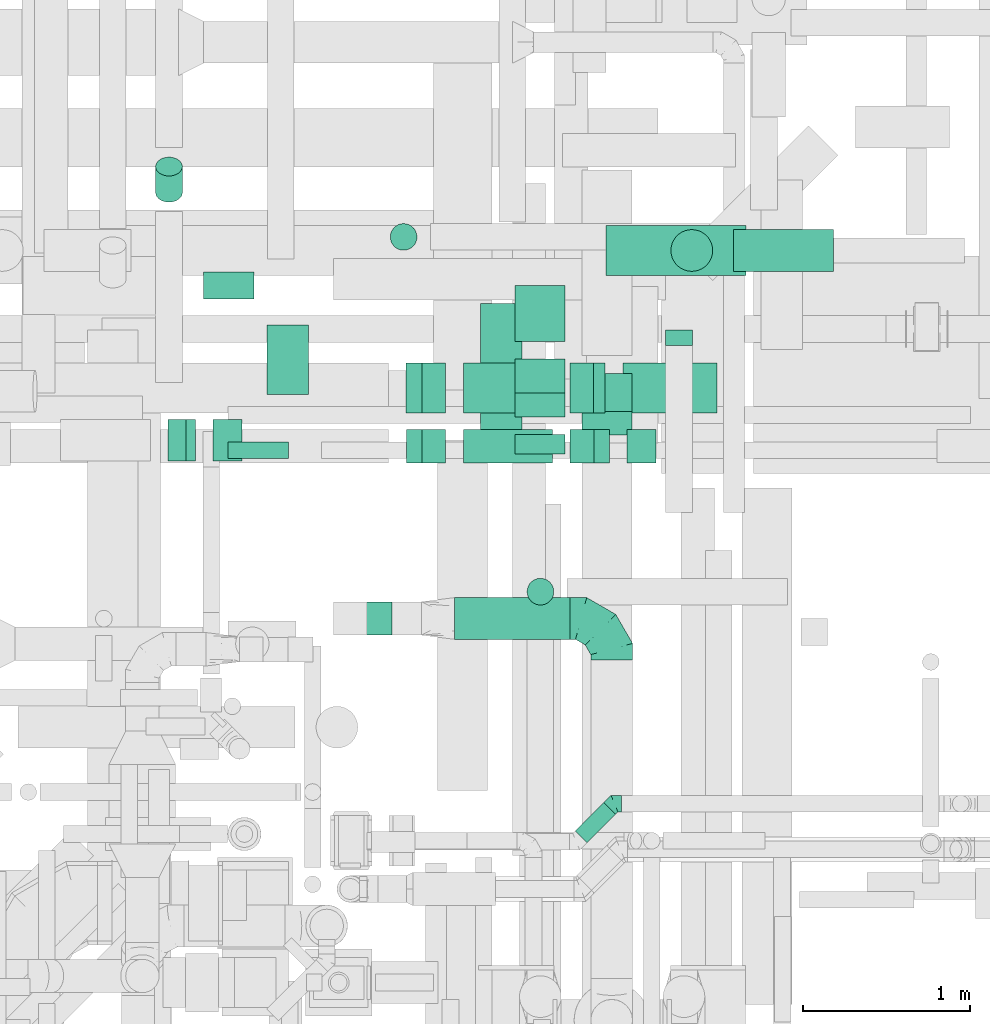
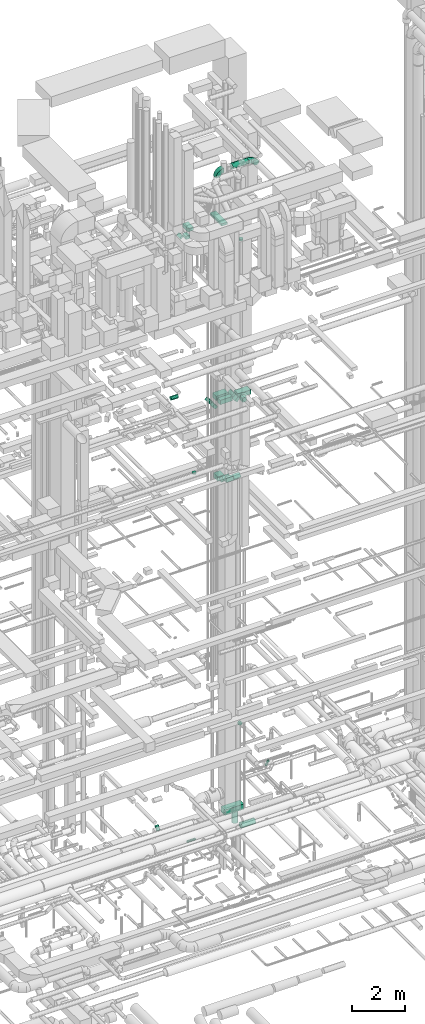
# One storey, part 251 of 337: 26 flow segments, 4 flow fittings.
"""IFC2X3 building model written with IfcOpenShell, lengths in millimetres."""

from ifc_helpers import new_model, entity, si_unit, converted_unit, derived_unit, direction, frame, frame_2d, origin, origin_2d_with_axis, place, context, subcontext, project, spatial, polyline, circle_curve, parameter, trimmed, segment, composite_curve, rectangle, circle, outline, extrude, faceted_brep, source, transform, mapped, material, type_object, type_shapes, element, save


model = new_model("IFC2X3")

# Units and contexts
model_context = context("Model", 3, precision=0.01, world=origin(), true_north=direction((6.12303176911189e-17, 1.0)))
body_context = subcontext(model_context, "Body", "Model", "MODEL_VIEW")
ifc_project = project(units=[si_unit("LENGTHUNIT", "METRE", prefix="MILLI"), si_unit("AREAUNIT", "SQUARE_METRE"), si_unit("VOLUMEUNIT", "CUBIC_METRE"), converted_unit("PLANEANGLEUNIT", "DEGREE", entity("IfcRatioMeasure", 0.0174532925199433), si_unit("PLANEANGLEUNIT", "RADIAN"), dimensions=[0, 0, 0, 0, 0, 0, 0]), si_unit("MASSUNIT", "GRAM", prefix="KILO"), derived_unit("MASSDENSITYUNIT", [(si_unit("MASSUNIT", "GRAM", prefix="KILO"), 1), (si_unit("LENGTHUNIT", "METRE"), -3)]), derived_unit("MOMENTOFINERTIAUNIT", [(si_unit("LENGTHUNIT", "METRE"), 4)]), si_unit("TIMEUNIT", "SECOND"), si_unit("FREQUENCYUNIT", "HERTZ"), si_unit("THERMODYNAMICTEMPERATUREUNIT", "DEGREE_CELSIUS"), derived_unit("THERMALTRANSMITTANCEUNIT", [(si_unit("MASSUNIT", "GRAM", prefix="KILO"), 1), (si_unit("THERMODYNAMICTEMPERATUREUNIT", "KELVIN"), -1), (si_unit("TIMEUNIT", "SECOND"), -3)]), derived_unit("VOLUMETRICFLOWRATEUNIT", [(si_unit("LENGTHUNIT", "METRE"), 3), (si_unit("TIMEUNIT", "SECOND"), -1)]), derived_unit("MASSFLOWRATEUNIT", [(si_unit("MASSUNIT", "GRAM", prefix="KILO"), 1), (si_unit("TIMEUNIT", "SECOND"), -1)]), derived_unit("ROTATIONALFREQUENCYUNIT", [(si_unit("TIMEUNIT", "SECOND"), -1)]), si_unit("ELECTRICCURRENTUNIT", "AMPERE"), si_unit("ELECTRICVOLTAGEUNIT", "VOLT"), si_unit("POWERUNIT", "WATT"), si_unit("FORCEUNIT", "NEWTON", prefix="KILO"), si_unit("ILLUMINANCEUNIT", "LUX"), si_unit("LUMINOUSFLUXUNIT", "LUMEN"), si_unit("LUMINOUSINTENSITYUNIT", "CANDELA"), derived_unit("USERDEFINED", [(si_unit("MASSUNIT", "GRAM", prefix="KILO"), -1), (si_unit("LENGTHUNIT", "METRE"), -2), (si_unit("TIMEUNIT", "SECOND"), 3), (si_unit("LUMINOUSFLUXUNIT", "LUMEN"), 1)]), derived_unit("LINEARVELOCITYUNIT", [(si_unit("LENGTHUNIT", "METRE"), 1), (si_unit("TIMEUNIT", "SECOND"), -1)]), si_unit("PRESSUREUNIT", "PASCAL"), derived_unit("USERDEFINED", [(si_unit("LENGTHUNIT", "METRE"), -2), (si_unit("MASSUNIT", "GRAM", prefix="KILO"), 1), (si_unit("TIMEUNIT", "SECOND"), -2)]), derived_unit("LINEARFORCEUNIT", [(si_unit("MASSUNIT", "GRAM", prefix="KILO"), 1), (si_unit("LENGTHUNIT", "METRE"), 1), (si_unit("TIMEUNIT", "SECOND"), -2), (si_unit("LENGTHUNIT", "METRE"), -1)]), derived_unit("PLANARFORCEUNIT", [(si_unit("MASSUNIT", "GRAM", prefix="KILO"), 1), (si_unit("LENGTHUNIT", "METRE"), 1), (si_unit("TIMEUNIT", "SECOND"), -2), (si_unit("LENGTHUNIT", "METRE"), -2)])], contexts=[model_context])

# Site, building, storey
site_placement = place(None, origin())
site = spatial("IfcSite", under=ifc_project, at=site_placement, CompositionType="ELEMENT")
building_placement = place(site_placement, origin())
building = spatial("IfcBuilding", under=site, at=building_placement, CompositionType="ELEMENT")
storey_placement = place(building_placement, origin())
storey = spatial("IfcBuildingStorey", under=building, at=storey_placement, CompositionType="ELEMENT", Elevation=0.0)

# Flow segments
duct_segment_type_1 = type_object("IfcDuctSegmentType", PredefinedType="NOTDEFINED")
flow_segment_1_placement = place(storey_placement, frame((61080.93, 15198.96, -975.0)))
element("IfcFlowSegment", 1, at=flow_segment_1_placement, inside=storey, type_object=duct_segment_type_1, context=body_context, shape_type="SweptSolid", body=[
    extrude(rectangle(XDim=839.433055887242, YDim=300.000000000001, at=origin_2d_with_axis()), frame((419.72, 150.0, 0.0)), (0.0, 0.0, 1.0), 250.0),
])
flow_segment_2_placement = place(storey_placement, frame((61208.02, 14075.53, 18750.0)))
element("IfcFlowSegment", 2, at=flow_segment_2_placement, inside=storey, type_object=duct_segment_type_1, context=body_context, shape_type="SweptSolid", body=[
    extrude(rectangle(XDim=172.037818770773, YDim=200.0, at=origin_2d_with_axis()), frame((86.02, 100.0, 0.0), z_axis=(0.0, 0.0, 1.0), x_axis=(-1.0, 0.0, 0.0)), (0.0, 0.0, 1.0), 200.000000000002),
])
flow_segment_3_placement = place(storey_placement, frame((60537.19, 14803.93, 14900.0)))
element("IfcFlowSegment", 3, at=flow_segment_3_placement, inside=storey, type_object=duct_segment_type_1, context=body_context, shape_type="SweptSolid", body=[
    extrude(rectangle(XDim=336.066847245268, YDim=300.000000000001, at=origin_2d_with_axis()), frame((150.0, 168.03, 0.0), z_axis=(0.0, 0.0, 1.0), x_axis=(0.0, -1.0, 0.0)), (0.0, 0.0, 1.0), 199.999999999998),
])
flow_segment_4_placement = place(storey_placement, frame((60537.19, 14129.66, 15250.0)))
element("IfcFlowSegment", 4, at=flow_segment_4_placement, inside=storey, type_object=duct_segment_type_1, context=body_context, shape_type="SweptSolid", body=[
    extrude(rectangle(XDim=117.166588713052, YDim=300.000000000001, at=origin_2d_with_axis()), frame((150.0, 58.58, 0.0), z_axis=(0.0, 0.0, 1.0), x_axis=(0.0, 1.0, 0.0)), (0.0, 0.0, 1.0), 199.999999999998),
])
flow_segment_5_placement = place(storey_placement, frame((60537.19, 14352.89, 15002.51)))
element("IfcFlowSegment", 5, at=flow_segment_5_placement, inside=storey, type_object=duct_segment_type_1, context=body_context, shape_type="SweptSolid", body=[
    extrude(rectangle(XDim=287.867907553649, YDim=200.000000000001, at=origin_2d_with_axis()), frame((0.0, 172.49, 172.49), z_axis=(1.0, 0.0, 0.0), x_axis=(0.0, 0.707106781186506, -0.707106781186589)), (0.0, 0.0, 1.0), 300.000000000001),
])
flow_segment_6_placement = place(storey_placement, frame((61182.64, 14375.32, 18775.0)))
element("IfcFlowSegment", 6, at=flow_segment_6_placement, inside=storey, type_object=duct_segment_type_1, context=body_context, shape_type="SweptSolid", body=[
    extrude(rectangle(XDim=562.010880577353, YDim=300.000000000001, at=origin_2d_with_axis()), frame((281.01, 150.0, 0.0)), (0.0, 0.0, 1.0), 200.000000000002),
])
flow_segment_7_placement = place(storey_placement, frame((59884.49, 14375.32, 18852.51)))
element("IfcFlowSegment", 7, at=flow_segment_7_placement, inside=storey, type_object=duct_segment_type_1, context=body_context, shape_type="SweptSolid", body=[
    extrude(rectangle(XDim=199.999999999995, YDim=133.794193046487, at=frame_2d((0.0, 0.0), x_axis=(0.0, 1.0))), frame((118.01, 0.0, 118.01), z_axis=(0.0, 1.0, 0.0), x_axis=(0.707106781186637, 0.0, 0.707106781186459)), (0.0, 0.0, 1.0), 299.999999999999),
])
flow_segment_8_placement = place(storey_placement, frame((60226.59, 14375.32, 18991.05)))
element("IfcFlowSegment", 8, at=flow_segment_8_placement, inside=storey, type_object=duct_segment_type_1, context=body_context, shape_type="SweptSolid", body=[
    extrude(rectangle(XDim=532.893218813475, YDim=300.000000000001, at=origin_2d_with_axis()), frame((266.45, 150.0, 0.0)), (0.0, 0.0, 1.0), 200.000000000002),
])
flow_segment_9_placement = place(storey_placement, frame((60865.55, 14375.32, 18877.51)))
element("IfcFlowSegment", 9, at=flow_segment_9_placement, inside=storey, type_object=duct_segment_type_1, context=body_context, shape_type="SweptSolid", body=[
    extrude(rectangle(XDim=200.000000000003, YDim=98.4388539871063, at=frame_2d((0.0, 0.0), x_axis=(0.0, 1.0))), frame((105.51, 0.0, 105.51), z_axis=(0.0, 1.0, 0.0), x_axis=(0.707106781186581, 0.0, -0.707106781186514)), (0.0, 0.0, 1.0), 300.000000000001),
])
flow_segment_10_placement = place(storey_placement, frame((59886.15, 14075.53, 18852.51)))
element("IfcFlowSegment", 10, at=flow_segment_10_placement, inside=storey, type_object=duct_segment_type_1, context=body_context, shape_type="SweptSolid", body=[
    extrude(rectangle(XDim=132.893218813456, YDim=200.0, at=origin_2d_with_axis()), frame((46.98, 100.0, 188.41), z_axis=(0.707106781186621, 0.0, -0.707106781186474), x_axis=(0.707106781186474, 0.0, 0.707106781186621)), (0.0, 0.0, 1.0), 200.000000000011),
])
flow_segment_11_placement = place(storey_placement, frame((60227.6, 14075.53, 18990.42)))
element("IfcFlowSegment", 11, at=flow_segment_11_placement, inside=storey, type_object=duct_segment_type_1, context=body_context, shape_type="SweptSolid", body=[
    extrude(rectangle(XDim=532.893218813526, YDim=200.0, at=origin_2d_with_axis()), frame((266.45, 100.0, 0.0)), (0.0, 0.0, 1.0), 200.000000000002),
])
flow_segment_12_placement = place(storey_placement, frame((60866.56, 14075.53, 18852.51)))
element("IfcFlowSegment", 12, at=flow_segment_12_placement, inside=storey, type_object=duct_segment_type_1, context=body_context, shape_type="SweptSolid", body=[
    extrude(rectangle(XDim=132.893218813424, YDim=200.000000000003, at=origin_2d_with_axis()), frame((117.7, 0.0, 117.7), z_axis=(0.0, 1.0, 0.0), x_axis=(0.70710678118645, 0.0, -0.707106781186645)), (0.0, 0.0, 1.0), 200.0),
])
flow_segment_13_placement = place(storey_placement, frame((60938.43, 14242.46, 14977.51)))
element("IfcFlowSegment", 13, at=flow_segment_13_placement, inside=storey, type_object=duct_segment_type_1, context=body_context, shape_type="SweptSolid", body=[
    extrude(rectangle(XDim=200.000000000001, YDim=300.000000000001, at=frame_2d((0.0, 0.0), x_axis=(0.0, 1.0))), frame((150.0, 299.26, 70.71), z_axis=(0.0, -0.707106781186493, 0.707106781186602), x_axis=(1.0, 0.0, 0.0)), (0.0, 0.0, 1.0), 323.222166174818),
])
flow_segment_14_placement = place(storey_placement, frame((59050.82, 14487.02, 27135.0)))
element("IfcFlowSegment", 14, at=flow_segment_14_placement, inside=storey, type_object=duct_segment_type_1, context=body_context, shape_type="SweptSolid", body=[
    extrude(rectangle(XDim=415.000000000072, YDim=250.000000000004, at=origin_2d_with_axis()), frame((125.0, 207.5, 0.0), z_axis=(0.0, 0.0, 1.0), x_axis=(0.0, 1.0, 0.0)), (0.0, 0.0, 1.0), 150.000000000001),
])
flow_segment_15_placement = place(storey_placement, frame((58458.69, 14087.02, 27222.87)))
element("IfcFlowSegment", 15, at=flow_segment_15_placement, inside=storey, type_object=duct_segment_type_1, context=body_context, shape_type="SweptSolid", body=[
    extrude(rectangle(XDim=82.3044737829602, YDim=149.999999999996, at=origin_2d_with_axis()), frame((82.13, 0.0, 82.13), z_axis=(0.0, 1.0, 0.0), x_axis=(0.707106781186442, 0.0, -0.707106781186653)), (0.0, 0.0, 1.0), 249.999999999997),
])
flow_segment_16_placement = place(storey_placement, frame((58729.02, 14087.02, 27135.0)))
element("IfcFlowSegment", 16, at=flow_segment_16_placement, inside=storey, type_object=duct_segment_type_1, context=body_context, shape_type="SweptSolid", body=[
    extrude(rectangle(XDim=171.801948466095, YDim=249.999999999999, at=origin_2d_with_axis()), frame((85.9, 125.0, 0.0), z_axis=(0.0, 0.0, 1.0), x_axis=(-1.0, 0.0, 0.0)), (0.0, 0.0, 1.0), 150.000000000001),
])
flow_segment_17_placement = place(storey_placement, frame((60328.86, 14152.02, 27160.0)))
element("IfcFlowSegment", 17, at=flow_segment_17_placement, inside=storey, type_object=duct_segment_type_1, context=body_context, shape_type="SweptSolid", body=[
    extrude(rectangle(XDim=879.999999999991, YDim=250.000000000004, at=origin_2d_with_axis()), frame((125.0, 440.0, 0.0), z_axis=(0.0, 0.0, 1.0), x_axis=(0.0, -1.0, 0.0)), (0.0, 0.0, 1.0), 100.000000000003),
])
duct_segment_type_2 = type_object("IfcDuctSegmentType", PredefinedType="NOTDEFINED")
flow_segment_18_placement = place(storey_placement, frame((61468.48, 15222.36, -1530.0)))
element("IfcFlowSegment", 18, at=flow_segment_18_placement, inside=storey, type_object=duct_segment_type_2, context=body_context, shape_type="SweptSolid", body=[
    extrude(circle(Radius=125.0, at=origin_2d_with_axis()), frame((126.6, 126.6, 0.0), z_axis=(0.0, 0.0, 1.0), x_axis=(-1.0, 0.0, 0.0)), (0.0, 0.0, 1.0), 535.000024999841),
])
flow_segment_19_placement = place(storey_placement, frame((61845.08, 15222.36, -1906.6)))
element("IfcFlowSegment", 19, at=flow_segment_19_placement, inside=storey, type_object=duct_segment_type_2, context=body_context, shape_type="SweptSolid", body=[
    extrude(circle(Radius=125.0, at=origin_2d_with_axis()), frame((0.0, 126.6, 126.6), z_axis=(1.0, 0.0, 0.0), x_axis=(0.0, -1.0, 0.0)), (0.0, 0.0, 1.0), 600.00000000002),
])
flow_segment_20_placement = place(storey_placement, frame((58816.63, 14101.68, -801.6)))
element("IfcFlowSegment", 20, at=flow_segment_20_placement, inside=storey, type_object=duct_segment_type_2, context=body_context, shape_type="SweptSolid", body=[
    extrude(circle(Radius=50.0, at=origin_2d_with_axis()), frame((0.0, 51.6, 51.6), z_axis=(1.0, 0.0, 0.0), x_axis=(0.0, -1.0, 0.0)), (0.0, 0.0, 1.0), 361.968535114356),
])
flow_segment_21_placement = place(storey_placement, frame((60895.92, 11799.78, 3398.4)))
element("IfcFlowSegment", 21, at=flow_segment_21_placement, inside=storey, type_object=duct_segment_type_2, context=body_context, shape_type="SweptSolid", body=[
    extrude(circle(Radius=50.0, at=origin_2d_with_axis()), frame((36.95, 36.95, 51.6), z_axis=(0.707106781186449, 0.707106781186647, 0.0), x_axis=(0.707106781186647, -0.707106781186449, 0.0)), (0.0, 0.0, 1.0), 240.588745030421),
])
flow_segment_22_placement = place(storey_placement, frame((58669.43, 15057.75, 19102.98)))
element("IfcFlowSegment", 22, at=flow_segment_22_placement, inside=storey, type_object=duct_segment_type_2, context=body_context, shape_type="SweptSolid", body=[
    extrude(circle(Radius=80.0, at=origin_2d_with_axis()), frame((0.0, 81.6, 81.6), z_axis=(1.0, 0.0, -2.32070423727223e-05), x_axis=(0.0, 1.0, 0.0)), (0.0, 0.0, 1.0), 305.163687991454),
])
flow_segment_23_placement = place(storey_placement, frame((59787.71, 15348.41, 15120.0)))
element("IfcFlowSegment", 23, at=flow_segment_23_placement, inside=storey, type_object=duct_segment_type_2, context=body_context, shape_type="SweptSolid", body=[
    extrude(circle(Radius=80.0, at=origin_2d_with_axis()), frame((81.6, 81.6, 0.0), z_axis=(0.0, 0.0, 1.0), x_axis=(0.0, 1.0, 0.0)), (0.0, 0.0, 1.0), 70.0000000000274),
])
flow_segment_24_placement = place(storey_placement, frame((60175.5, 13018.64, 30473.4)))
element("IfcFlowSegment", 24, at=flow_segment_24_placement, inside=storey, type_object=duct_segment_type_2, context=body_context, shape_type="SweptSolid", body=[
    extrude(circle(Radius=125.0, at=origin_2d_with_axis()), frame((0.0, 126.6, 126.6), z_axis=(1.0, 0.0, 0.0), x_axis=(0.0, 1.0, 0.0)), (0.0, 0.0, 1.0), 689.797516888803),
])
flow_segment_25_placement = place(storey_placement, frame((60607.25, 13224.03, 26910.0)))
element("IfcFlowSegment", 25, at=flow_segment_25_placement, inside=storey, type_object=duct_segment_type_2, context=body_context, shape_type="SweptSolid", body=[
    extrude(circle(Radius=80.0, at=origin_2d_with_axis()), frame((81.6, 81.6, 0.0), z_axis=(0.0, 0.0, 1.0), x_axis=(-1.0, 0.0, 0.0)), (0.0, 0.0, 1.0), 90.0000000000272),
])
flow_segment_26_placement = place(storey_placement, frame((58382.55, 15636.95, -1111.3)))
element("IfcFlowSegment", 26, at=flow_segment_26_placement, inside=storey, type_object=duct_segment_type_2, context=body_context, shape_type="SweptSolid", body=[
    extrude(circle(Radius=80.0, at=origin_2d_with_axis()), frame((81.6, 58.16, 58.16), z_axis=(0.0, 0.707106781186494, 0.707106781186601), x_axis=(-1.0, 0.0, 0.0)), (0.0, 0.0, 1.0), 221.005016763214),
])

# Flow fittings
ifc_material = material()
duct_fitting_type_1 = type_object("IfcDuctFittingType", PredefinedType="NOTDEFINED", material=ifc_material)
shared_shape_1 = source(origin(), body_context, "Body", "Brep", [
    faceted_brep([(-250.0, 0.0, -125.0), (-250.0, -32.35, -120.74), (-250.0, -62.5, -108.25), (-250.0, -88.39, -88.39), (-250.0, -108.25, -62.5), (-250.0, -120.74, -32.35), (-250.0, -125.0, 0.0), (-250.0, -120.74, 32.35), (-250.0, -108.25, 62.5), (-250.0, -88.39, 88.39), (-250.0, -62.5, 108.25), (-250.0, -32.35, 120.74), (-250.0, 0.0, 125.0), (-250.0, 32.35, 120.74), (-250.0, 62.5, 108.25), (-250.0, 88.39, 88.39), (-250.0, 108.25, 62.5), (-250.0, 120.74, 32.35), (-250.0, 125.0, 0.0), (-250.0, 120.74, -32.35), (-250.0, 108.25, -62.5), (-250.0, 88.39, -88.39), (-250.0, 62.5, -108.25), (-250.0, 32.35, -120.74), (-191.68, 32.35, 120.74), (-199.76, 62.5, 108.25), (-183.01, 0.0, 125.0), (-206.7, 88.39, 88.39), (-215.37, 120.74, 32.35), (-216.51, 125.0, 0.0), (-212.02, 108.25, 62.5), (-212.02, 108.25, -62.5), (-206.7, 88.39, -88.39), (-215.37, 120.74, -32.35), (-191.68, 32.35, -120.74), (-183.01, 0.0, -125.0), (-199.76, 62.5, -108.25), (-174.34, -32.35, -120.74), (-166.27, -62.5, -108.25), (-159.33, -88.39, -88.39), (-154.01, -108.25, -62.5), (-150.66, -120.74, -32.35), (-149.52, -125.0, 0.0), (-150.66, -120.74, 32.35), (-154.01, -108.25, 62.5), (-159.33, -88.39, 88.39), (-166.27, -62.5, 108.25), (-174.34, -32.35, 120.74), (-90.67, 90.67, 120.74), (-112.74, 112.74, 108.25), (-66.99, 66.99, 125.0), (-131.69, 131.69, 88.39), (-146.23, 146.23, 62.5), (-155.38, 155.38, 32.35), (-158.49, 158.49, 0.0), (-155.38, 155.38, -32.35), (-146.23, 146.23, -62.5), (-131.69, 131.69, -88.39), (-90.67, 90.67, -120.74), (-66.99, 66.99, -125.0), (-112.74, 112.74, -108.25), (-43.3, 43.3, -120.74), (-21.23, 21.23, -108.25), (-2.28, 2.28, -88.39), (12.26, -12.26, -62.5), (21.4, -21.4, -32.35), (24.52, -24.52, 0.0), (21.4, -21.4, 32.35), (12.26, -12.26, 62.5), (-2.28, 2.28, 88.39), (-21.23, 21.23, 108.25), (-43.3, 43.3, 120.74), (-32.35, 191.68, 120.74), (-62.5, 199.76, 108.25), (0.0, 183.01, 125.0), (-88.39, 206.7, 88.39), (-108.25, 212.02, 62.5), (-120.74, 215.37, 32.35), (-125.0, 216.51, 0.0), (-120.74, 215.37, -32.35), (-108.25, 212.02, -62.5), (-88.39, 206.7, -88.39), (-32.35, 191.68, -120.74), (0.0, 183.01, -125.0), (-62.5, 199.76, -108.25), (32.35, 174.34, -120.74), (62.5, 166.27, -108.25), (88.39, 159.33, -88.39), (108.25, 154.01, -62.5), (120.74, 150.66, -32.35), (125.0, 149.52, 0.0), (120.74, 150.66, 32.35), (108.25, 154.01, 62.5), (88.39, 159.33, 88.39), (62.5, 166.27, 108.25), (32.35, 174.34, 120.74), (-32.35, 250.0, -120.74), (-62.5, 250.0, -108.25), (-88.39, 250.0, -88.39), (-108.25, 250.0, -62.5), (-120.74, 250.0, -32.35), (-125.0, 250.0, 0.0), (-120.74, 250.0, 32.35), (-108.25, 250.0, 62.5), (-88.39, 250.0, 88.39), (-62.5, 250.0, 108.25), (-32.35, 250.0, 120.74), (0.0, 250.0, 125.0), (32.35, 250.0, 120.74), (62.5, 250.0, 108.25), (88.39, 250.0, 88.39), (108.25, 250.0, 62.5), (120.74, 250.0, 32.35), (125.0, 250.0, 0.0), (120.74, 250.0, -32.35), (108.25, 250.0, -62.5), (88.39, 250.0, -88.39), (62.5, 250.0, -108.25), (32.35, 250.0, -120.74), (0.0, 250.0, -125.0)], [[[0, 1, 2, 3, 4, 5, 6, 7, 8, 9, 10, 11, 12, 13, 14, 15, 16, 17, 18, 19, 20, 21, 22, 23]], [[24, 25, 14, 13]], [[26, 24, 13, 12]], [[14, 25, 27, 15]], [[28, 29, 18, 17]], [[30, 28, 17, 16]], [[15, 27, 30, 16]], [[20, 31, 32, 21]], [[33, 31, 20, 19]], [[18, 29, 33, 19]], [[34, 35, 0, 23]], [[36, 34, 23, 22]], [[21, 32, 36, 22]], [[1, 0, 35, 37]], [[2, 1, 37, 38]], [[38, 39, 3, 2]], [[5, 4, 40, 41]], [[6, 5, 41, 42]], [[39, 40, 4, 3]], [[6, 42, 43, 7]], [[7, 43, 44, 8]], [[8, 44, 45, 9]], [[9, 45, 46, 10]], [[10, 46, 47, 11]], [[26, 12, 11, 47]], [[48, 49, 25, 24]], [[50, 48, 24, 26]], [[27, 25, 49, 51]], [[52, 53, 28, 30]], [[51, 52, 30, 27]], [[29, 28, 53, 54]], [[55, 56, 31, 33]], [[54, 55, 33, 29]], [[32, 31, 56, 57]], [[58, 59, 35, 34]], [[60, 58, 34, 36]], [[57, 60, 36, 32]], [[37, 35, 59, 61]], [[38, 37, 61, 62]], [[39, 38, 62, 63]], [[41, 40, 64, 65]], [[42, 41, 65, 66]], [[63, 64, 40, 39]], [[43, 42, 66, 67]], [[44, 43, 67, 68]], [[68, 69, 45, 44]], [[46, 45, 69, 70]], [[47, 46, 70, 71]], [[26, 47, 71, 50]], [[72, 73, 49, 48]], [[74, 72, 48, 50]], [[51, 49, 73, 75]], [[76, 77, 53, 52]], [[75, 76, 52, 51]], [[54, 53, 77, 78]], [[79, 80, 56, 55]], [[78, 79, 55, 54]], [[57, 56, 80, 81]], [[82, 83, 59, 58]], [[84, 82, 58, 60]], [[81, 84, 60, 57]], [[61, 59, 83, 85]], [[62, 61, 85, 86]], [[63, 62, 86, 87]], [[65, 64, 88, 89]], [[66, 65, 89, 90]], [[87, 88, 64, 63]], [[67, 66, 90, 91]], [[68, 67, 91, 92]], [[92, 93, 69, 68]], [[70, 69, 93, 94]], [[71, 70, 94, 95]], [[50, 71, 95, 74]], [[96, 97, 98, 99, 100, 101, 102, 103, 104, 105, 106, 107, 108, 109, 110, 111, 112, 113, 114, 115, 116, 117, 118, 119]], [[72, 74, 107, 106]], [[73, 72, 106, 105]], [[75, 73, 105, 104]], [[77, 76, 103, 102]], [[78, 77, 102, 101]], [[75, 104, 103, 76]], [[78, 101, 100, 79]], [[79, 100, 99, 80]], [[80, 99, 98, 81]], [[84, 97, 96, 82]], [[82, 96, 119, 83]], [[84, 81, 98, 97]], [[83, 119, 118, 85]], [[85, 118, 117, 86]], [[116, 87, 86, 117]], [[88, 115, 114, 89]], [[89, 114, 113, 90]], [[115, 88, 87, 116]], [[91, 90, 113, 112]], [[92, 91, 112, 111]], [[111, 110, 93, 92]], [[95, 94, 109, 108]], [[74, 95, 108, 107]], [[110, 109, 94, 93]]]),
])
type_shapes(duct_fitting_type_1, [shared_shape_1])
flow_fitting_1_placement = place(storey_placement, frame((61115.3, 13145.23, 30600.0), z_axis=(0.0, 0.0, 1.0), x_axis=(0.0, 1.0, 0.0)))
element("IfcFlowFitting", 27, at=flow_fitting_1_placement, inside=storey, type_object=duct_fitting_type_1, material=ifc_material, context=body_context, shape_type="MappedRepresentation", body=[
    mapped(shared_shape_1, transform((0.0, 0.0, 0.0), scale=1.0)),
])
duct_fitting_type_2 = type_object("IfcDuctFittingType", PredefinedType="NOTDEFINED", material=ifc_material)
shared_shape_2 = source(origin(), body_context, "Body", "Brep", [
    faceted_brep([(-41.42, 0.0, -50.0), (-41.42, -12.94, -48.3), (-41.42, -25.0, -43.3), (-41.42, -35.36, -35.36), (-41.42, -43.3, -25.0), (-41.42, -48.3, -12.94), (-41.42, -50.0, 0.0), (-41.42, -48.3, 12.94), (-41.42, -43.3, 25.0), (-41.42, -35.36, 35.36), (-41.42, -25.0, 43.3), (-41.42, -12.94, 48.3), (-41.42, 0.0, 50.0), (-41.42, 12.94, 48.3), (-41.42, 25.0, 43.3), (-41.42, 35.36, 35.36), (-41.42, 43.3, 25.0), (-41.42, 48.3, 12.94), (-41.42, 50.0, 0.0), (-41.42, 48.3, -12.94), (-41.42, 43.3, -25.0), (-41.42, 35.36, -35.36), (-41.42, 25.0, -43.3), (-41.42, 12.94, -48.3), (-5.36, 12.94, 48.3), (-10.36, 25.0, 43.3), (0.0, 0.0, 50.0), (-14.64, 35.36, 35.36), (-20.0, 48.3, 12.94), (-20.71, 50.0, 0.0), (-17.94, 43.3, 25.0), (-17.94, 43.3, -25.0), (-14.64, 35.36, -35.36), (-20.0, 48.3, -12.94), (-5.36, 12.94, -48.3), (0.0, 0.0, -50.0), (-10.36, 25.0, -43.3), (5.36, -12.94, -48.3), (10.36, -25.0, -43.3), (14.64, -35.36, -35.36), (17.94, -43.3, -25.0), (20.0, -48.3, -12.94), (20.71, -50.0, 0.0), (20.0, -48.3, 12.94), (17.94, -43.3, 25.0), (14.64, -35.36, 35.36), (10.36, -25.0, 43.3), (5.36, -12.94, 48.3), (29.29, 29.29, 50.0), (20.14, 38.44, 48.3), (11.61, 46.97, 43.3), (4.29, 54.29, 35.36), (-1.33, 59.91, 25.0), (-4.86, 63.44, 12.94), (-6.07, 64.64, 0.0), (-4.86, 63.44, -12.94), (-1.33, 59.91, -25.0), (4.29, 54.29, -35.36), (11.61, 46.97, -43.3), (20.14, 38.44, -48.3), (29.29, 29.29, -50.0), (38.44, 20.14, -48.3), (46.97, 11.61, -43.3), (54.29, 4.29, -35.36), (59.91, -1.33, -25.0), (63.44, -4.86, -12.94), (64.64, -6.07, 0.0), (63.44, -4.86, 12.94), (59.91, -1.33, 25.0), (54.29, 4.29, 35.36), (46.97, 11.61, 43.3), (38.44, 20.14, 48.3)], [[[0, 1, 2, 3, 4, 5, 6, 7, 8, 9, 10, 11, 12, 13, 14, 15, 16, 17, 18, 19, 20, 21, 22, 23]], [[24, 25, 14, 13]], [[26, 24, 13, 12]], [[14, 25, 27, 15]], [[28, 29, 18, 17]], [[30, 28, 17, 16]], [[16, 15, 27, 30]], [[20, 31, 32, 21]], [[33, 31, 20, 19]], [[18, 29, 33, 19]], [[34, 35, 0, 23]], [[36, 34, 23, 22]], [[32, 36, 22, 21]], [[1, 0, 35, 37]], [[2, 1, 37, 38]], [[38, 39, 3, 2]], [[5, 4, 40, 41]], [[6, 5, 41, 42]], [[39, 40, 4, 3]], [[6, 42, 43, 7]], [[7, 43, 44, 8]], [[8, 44, 45, 9]], [[9, 45, 46, 10]], [[10, 46, 47, 11]], [[26, 12, 11, 47]], [[24, 26, 48, 49]], [[25, 24, 49, 50]], [[27, 25, 50, 51]], [[28, 30, 52, 53]], [[29, 28, 53, 54]], [[27, 51, 52, 30]], [[29, 54, 55, 33]], [[33, 55, 56, 31]], [[31, 56, 57, 32]], [[36, 58, 59, 34]], [[34, 59, 60, 35]], [[36, 32, 57, 58]], [[61, 62, 38, 37]], [[60, 61, 37, 35]], [[63, 39, 38, 62]], [[40, 64, 65, 41]], [[41, 65, 66, 42]], [[64, 40, 39, 63]], [[43, 42, 66, 67]], [[44, 43, 67, 68]], [[68, 69, 45, 44]], [[47, 46, 70, 71]], [[26, 47, 71, 48]], [[69, 70, 46, 45]], [[59, 58, 57, 56, 55, 54, 53, 52, 51, 50, 49, 48, 71, 70, 69, 68, 67, 66, 65, 64, 63, 62, 61, 60]]]),
])
type_shapes(duct_fitting_type_2, [shared_shape_2])
flow_fitting_2_placement = place(storey_placement, frame((61132.28, 12036.14, 3450.0), z_axis=(0.0, 0.0, 1.0), x_axis=(-1.0, 0.0, 0.0)))
element("IfcFlowFitting", 28, at=flow_fitting_2_placement, inside=storey, type_object=duct_fitting_type_2, material=ifc_material, context=body_context, shape_type="MappedRepresentation", body=[
    mapped(shared_shape_2, transform((0.0, 0.0, 0.0), scale=1.0)),
])
duct_fitting_type_3 = type_object("IfcDuctFittingType", PredefinedType="NOTDEFINED", material=ifc_material)
shared_shape_3 = source(origin(), body_context, "Body", "Brep", [
    faceted_brep([(20.0, 0.0, -80.0), (20.0, 20.71, -77.27), (20.0, 40.0, -69.28), (20.0, 56.57, -56.57), (20.0, 69.28, -40.0), (20.0, 77.27, -20.71), (20.0, 80.0, 0.0), (20.0, 77.27, 20.71), (20.0, 69.28, 40.0), (20.0, 56.57, 56.57), (20.0, 40.0, 69.28), (20.0, 20.71, 77.27), (20.0, 0.0, 80.0), (20.0, -20.71, 77.27), (20.0, -40.0, 69.28), (20.0, -56.57, 56.57), (20.0, -69.28, 40.0), (20.0, -77.27, 20.71), (20.0, -80.0, 0.0), (20.0, -77.27, -20.71), (20.0, -69.28, -40.0), (20.0, -56.57, -56.57), (20.0, -40.0, -69.28), (20.0, -20.71, -77.27), (0.0, 0.0, 80.0), (-73.9, 0.0, 80.0), (-73.9, -20.71, 77.27), (0.0, -20.71, 77.27), (-73.9, -40.0, 69.28), (0.0, -40.0, 69.28), (0.0, -56.57, 56.57), (-73.9, -56.57, 56.57), (0.0, -69.28, 40.0), (-73.9, -69.28, 40.0), (-73.9, -77.27, 20.71), (0.0, -77.27, 20.71), (-73.9, -80.0, 0.0), (0.0, -80.0, 0.0), (-73.9, -77.27, -20.71), (0.0, -77.27, -20.71), (-73.9, -69.28, -40.0), (0.0, -69.28, -40.0), (0.0, -56.57, -56.57), (-73.9, -56.57, -56.57), (0.0, -40.0, -69.28), (-73.9, -40.0, -69.28), (-73.9, -20.71, -77.27), (0.0, -20.71, -77.27), (-73.9, 0.0, -80.0), (0.0, 0.0, -80.0), (-73.9, 20.71, -77.27), (0.0, 20.71, -77.27), (-73.9, 40.0, -69.28), (0.0, 40.0, -69.28), (0.0, 56.57, -56.57), (-73.9, 56.57, -56.57), (0.0, 69.28, -40.0), (-73.9, 69.28, -40.0), (-73.9, 77.27, -20.71), (0.0, 77.27, -20.71), (-73.9, 80.0, 0.0), (0.0, 80.0, 0.0), (-73.9, 77.27, 20.71), (0.0, 77.27, 20.71), (-73.9, 69.28, 40.0), (0.0, 69.28, 40.0), (0.0, 56.57, 56.57), (-73.9, 56.57, 56.57), (0.0, 40.0, 69.28), (-73.9, 40.0, 69.28), (-73.9, 20.71, 77.27), (0.0, 20.71, 77.27)], [[[0, 1, 2, 3, 4, 5, 6, 7, 8, 9, 10, 11, 12, 13, 14, 15, 16, 17, 18, 19, 20, 21, 22, 23]], [[13, 12, 24, 25, 26, 27]], [[14, 13, 27, 26, 28, 29]], [[30, 15, 14, 29, 28, 31]], [[17, 16, 32, 33, 34, 35]], [[18, 17, 35, 34, 36, 37]], [[32, 16, 15, 30, 31, 33]], [[19, 18, 37, 36, 38, 39]], [[20, 19, 39, 38, 40, 41]], [[42, 21, 20, 41, 40, 43]], [[23, 22, 44, 45, 46, 47]], [[0, 23, 47, 46, 48, 49]], [[44, 22, 21, 42, 43, 45]], [[1, 0, 49, 48, 50, 51]], [[2, 1, 51, 50, 52, 53]], [[54, 3, 2, 53, 52, 55]], [[5, 4, 56, 57, 58, 59]], [[6, 5, 59, 58, 60, 61]], [[56, 4, 3, 54, 55, 57]], [[7, 6, 61, 60, 62, 63]], [[8, 7, 63, 62, 64, 65]], [[66, 9, 8, 65, 64, 67]], [[11, 10, 68, 69, 70, 71]], [[12, 11, 71, 70, 25, 24]], [[68, 10, 9, 66, 67, 69]], [[46, 45, 43, 40, 38, 36, 34, 33, 31, 28, 26, 25, 70, 69, 67, 64, 62, 60, 58, 57, 55, 52, 50, 48]]]),
])
type_shapes(duct_fitting_type_3, [shared_shape_3])
flow_fitting_3_placement = place(storey_placement, frame((61518.88, 14798.74, 3380.0), z_axis=(0.0, 0.0, -1.0), x_axis=(0.0, -1.0, 0.0)))
element("IfcFlowFitting", 29, at=flow_fitting_3_placement, inside=storey, type_object=duct_fitting_type_3, material=ifc_material, context=body_context, shape_type="MappedRepresentation", body=[
    mapped(shared_shape_3, transform((0.0, 0.0, 0.0), scale=1.0)),
])
duct_fitting_type_4 = type_object("IfcDuctFittingType", PredefinedType="NOTDEFINED", material=ifc_material)
shared_shape_4 = source(origin(), body_context, "Body", "SweptSolid", [
    extrude(outline(composite_curve([segment(polyline([(-225.0, -125.0), (-25.0, -125.0)]), True, "CONTINUOUS"), segment(trimmed(circle_curve(frame_2d((125.0, -125.0), x_axis=(0.0, 1.0)), 150.0), [parameter(0.0)], [parameter(90.0)], True, "PARAMETER"), False, "CONTINUOUS"), segment(polyline([(125.0, 25.0), (125.0, 225.0)]), True, "CONTINUOUS"), segment(trimmed(circle_curve(frame_2d((125.0, -125.0), x_axis=(0.0, 1.0)), 350.0), [parameter(0.0)], [parameter(90.0)], True, "PARAMETER"), True, "CONTINUOUS")], self_intersect=False)), frame((-125.0, 125.0, -100.0), z_axis=(0.0, 0.0, 1.0), x_axis=(-1.0, 0.0, 0.0)), (0.0, 0.0, 1.0), 200.0),
])
type_shapes(duct_fitting_type_4, [shared_shape_4])
flow_fitting_4_placement = place(storey_placement, frame((59549.99, 13145.23, 30600.0), z_axis=(0.0, -1.0, 0.0), x_axis=(-1.0, 0.0, 0.0)))
element("IfcFlowFitting", 30, at=flow_fitting_4_placement, inside=storey, type_object=duct_fitting_type_4, material=ifc_material, context=body_context, shape_type="MappedRepresentation", body=[
    mapped(shared_shape_4, transform((0.0, 0.0, 0.0), scale=1.0)),
])

save(model, "model.ifc")
